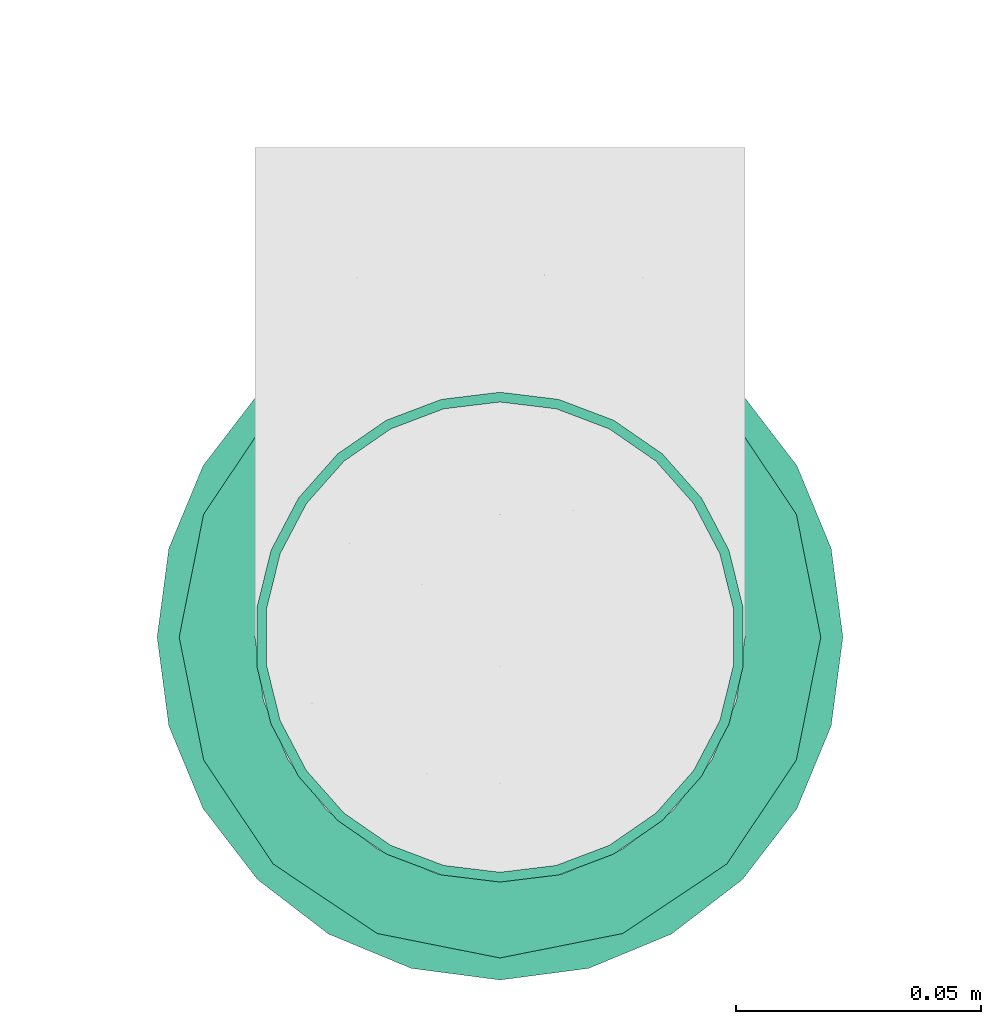
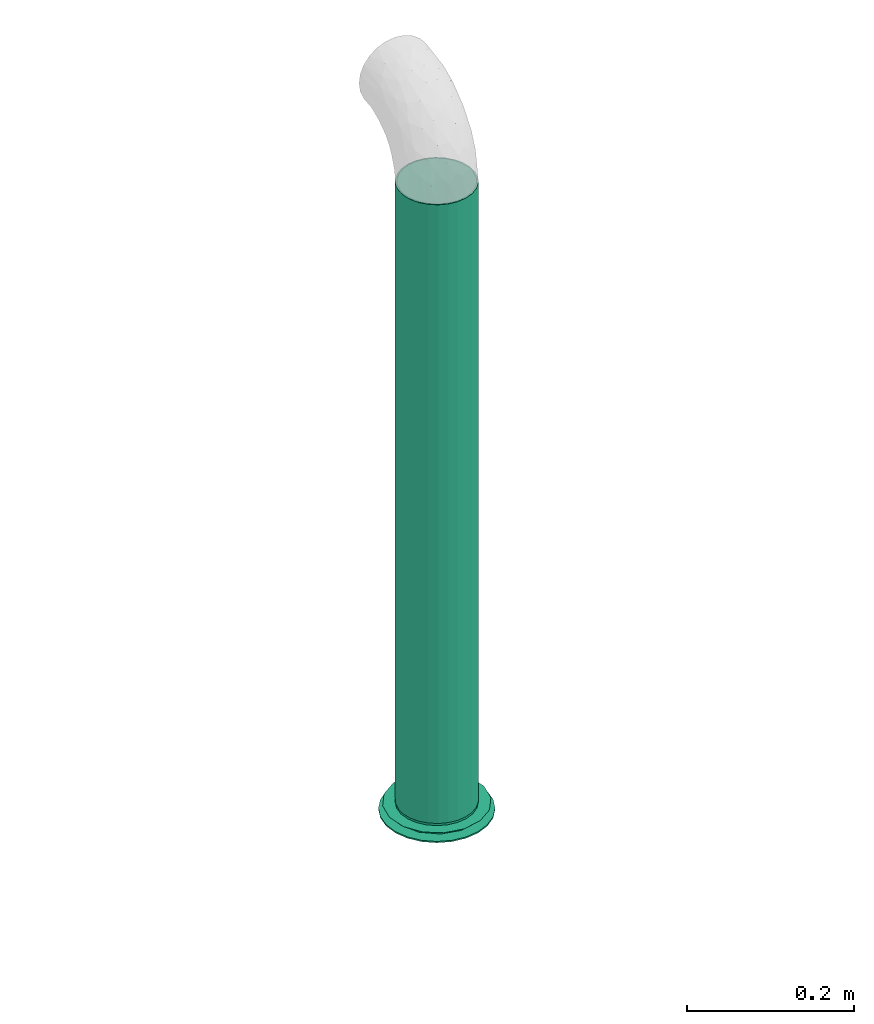
# One storey, part 49 of 103: 1 flow segment, 1 flow terminal.
"""IFC2X3 building model written with IfcOpenShell, lengths in millimetres."""

from ifc_helpers import new_model, entity, si_unit, converted_unit, derived_unit, direction, frame, origin_with_axes, origin_2d_with_axis, place, context, subcontext, project, spatial, hollow_circle, extrude, open_shell, surface_model, source, transform, mapped, material, layer, layer_set, layer_usage, type_object, element, save


model = new_model("IFC2X3")

# Units and contexts
model_context = context("Model", 3, precision=1e-05, world=origin_with_axes(), true_north=direction((0.0, 1.0)))
body_context = subcontext(model_context, "Body", "Model", "MODEL_VIEW")
ifc_project = project(units=[si_unit("AREAUNIT", "SQUARE_METRE"), si_unit("VOLUMEUNIT", "CUBIC_METRE", prefix="DECI"), si_unit("TIMEUNIT", "SECOND"), si_unit("THERMODYNAMICTEMPERATUREUNIT", "DEGREE_CELSIUS"), si_unit("PRESSUREUNIT", "PASCAL"), si_unit("MASSUNIT", "GRAM", prefix="KILO"), si_unit("LENGTHUNIT", "METRE", prefix="MILLI"), si_unit("POWERUNIT", "WATT"), si_unit("ELECTRICCURRENTUNIT", "AMPERE"), si_unit("ELECTRICVOLTAGEUNIT", "VOLT"), derived_unit("VOLUMETRICFLOWRATEUNIT", [(si_unit("VOLUMEUNIT", "CUBIC_METRE", prefix="DECI"), 1), (si_unit("TIMEUNIT", "SECOND"), -1)]), derived_unit("LINEARVELOCITYUNIT", [(si_unit("LENGTHUNIT", "METRE"), 1), (si_unit("TIMEUNIT", "SECOND"), -1)]), derived_unit("MASSDENSITYUNIT", [(si_unit("MASSUNIT", "GRAM", prefix="KILO"), 1), (si_unit("VOLUMEUNIT", "CUBIC_METRE"), -1)]), converted_unit("PLANEANGLEUNIT", "DEGREE", entity("IfcRatioMeasure", 0.01745), si_unit("PLANEANGLEUNIT", "RADIAN"), dimensions=[0, 0, 0, 0, 0, 0, 0])], contexts=[model_context])

# Site, building, storey
site_placement = place(None, origin_with_axes())
site = spatial("IfcSite", under=ifc_project, at=site_placement, CompositionType="ELEMENT")
building_placement = place(site_placement, origin_with_axes())
building = spatial("IfcBuilding", under=site, at=building_placement, Name="mc-building", CompositionType="ELEMENT")
storey_placement = place(building_placement, frame((0.0, 0.0, 5900.0), z_axis=(0.0, 0.0, 1.0), x_axis=(1.0, 0.0, 0.0)))
storey = spatial("IfcBuildingStorey", under=building, at=storey_placement, Name="3. Korrus", CompositionType="ELEMENT", Elevation=5900.0)

# Flow segment
ifc_material = material(Name="FZ1")
ifc_layer = layer(ifc_material, 0.0)
ifc_layer_set = layer_set([ifc_layer], Name="FZ1")
ifc_layer_usage = layer_usage(ifc_layer_set, "AXIS1", "POSITIVE", 0.0)
duct_segment_type = type_object("IfcDuctSegmentType", Name="Safe", PredefinedType="RIGIDSEGMENT")
shared_shape_1 = source(origin_with_axes(), body_context, "Body", "SweptSolid", [
    extrude(hollow_circle(Radius=50.0, WallThickness=2.0, at=origin_2d_with_axis()), frame((0.0, 0.0, 0.0), z_axis=(1.0, 0.0, 0.0), x_axis=(0.0, 1.0, 0.0)), (0.0, 0.0, 1.0), 906.0),
])
flow_segment_placement = place(storey_placement, frame((18753.74821, 573.88887, 2461.97044), z_axis=(1.0, 0.0, 0.0), x_axis=(0.0, 0.0, 1.0)))
element("IfcFlowSegment", 1, at=flow_segment_placement, inside=storey, type_object=duct_segment_type, material=ifc_layer_usage, Name="Safe", context=body_context, shape_type="MappedRepresentation", body=[
    mapped(shared_shape_1, transform((0.0, 0.0, 0.0), scale=1.0)),
])

# Flow terminal
air_terminal_type = type_object("IfcAirTerminalType", Name="100", PredefinedType="NOTDEFINED")
shared_shape_2 = source(origin_with_axes(), body_context, "Body", "SurfaceModel", [
    surface_model("IfcShellBasedSurfaceModel", [(11.2, -70.0, 0.0), (11.2, -67.61481, -18.11733), (11.2, -67.61481, 18.11733), (6.2, -14.64625, -20.15883), (9.2, -22.36867, -22.36867), (6.2, -21.19625, -15.39997), (9.2, 16.375, -28.36233), (6.2, 8.09625, -24.91768), (6.2, 14.64625, -20.15883), (6.2, -8.09625, -24.91768), (9.2, -16.375, -28.36233), (6.2, 21.19625, -15.39997), (9.2, 22.36867, -22.36867), (9.2, -8.1875, -30.55617), (9.2, 8.1875, -30.55617), (9.2, 28.36233, -16.375), (9.2, -28.36233, -16.375), (6.2, 14.64625, 20.15883), (9.2, 22.36867, 22.36867), (6.2, 21.19625, 15.39997), (9.2, -16.375, 28.36233), (6.2, -8.09625, 24.91768), (6.2, -14.64625, 20.15883), (6.2, 8.09625, 24.91768), (9.2, 16.375, 28.36233), (6.2, -21.19625, 15.39997), (9.2, -22.36867, 22.36867), (9.2, 8.1875, 30.55617), (9.2, -8.1875, 30.55617), (9.2, -28.36233, 16.375), (9.2, 28.36233, 16.375), (6.2, -53.11211, -25.57744), (6.2, -36.75472, -46.08897), (6.2, -13.11761, -57.472), (6.2, 13.11761, -57.472), (6.2, 36.75472, -46.08897), (6.2, 53.11211, -25.57744), (0.0, -12.53288, -63.00706), (6.2, 0.0, -57.472), (0.0, -46.3155, -46.3155), (0.0, -35.69063, -53.4148), (0.0, 0.0, -65.5), (6.2, 44.93342, -35.83321), (0.0, 46.3155, -46.3155), (0.0, 35.69063, -53.4148), (6.2, -44.93342, -35.83321), (0.0, 12.53288, -63.00706), (0.0, 25.06576, -60.51411), (6.2, 56.03105, -12.78872), (0.0, 60.51411, -25.06576), (0.0, 63.00706, -12.53288), (0.0, 53.4148, -35.69063), (0.0, -25.06576, -60.51411), (0.0, -63.00706, -12.53288), (0.0, -60.51411, -25.06576), (6.2, -56.03105, -12.78872), (0.0, -53.4148, -35.69063), (6.2, 13.11761, 57.472), (0.0, 12.53288, 63.00706), (6.2, 0.0, 57.472), (6.2, 36.75472, 46.08897), (0.0, 46.3155, 46.3155), (0.0, 35.69063, 53.4148), (0.0, 0.0, 65.5), (6.2, -44.93342, 35.83321), (6.2, -36.75472, 46.08897), (0.0, -46.3155, 46.3155), (0.0, -35.69063, 53.4148), (6.2, 44.93342, 35.83321), (0.0, -12.53288, 63.00706), (0.0, -25.06576, 60.51411), (6.2, -13.11761, 57.472), (6.2, -56.03105, 12.78872), (0.0, -60.51411, 25.06576), (0.0, -63.00706, 12.53288), (0.0, -53.4148, 35.69063), (0.0, 25.06576, 60.51411), (0.0, 63.00706, 12.53288), (0.0, 60.51411, 25.06576), (6.2, 56.03105, 12.78872), (0.0, 53.4148, 35.69063), (-3.1, 43.30127, 25.0), (-3.1, -48.29629, -12.94095), (-3.1, -43.30127, 25.0), (-3.1, 25.0, -43.30127), (-3.1, 48.29629, -12.94095), (-3.1, 35.35534, -35.35534), (-3.1, -35.35534, -35.35534), (-3.1, -25.0, -43.30127), (-43.1, 43.46666, 11.64686), (-3.1, 38.97115, 22.5), (-3.1, 43.46666, 11.64686), (-3.1, 45.0, 0.0), (-43.1, 45.0, 0.0), (-3.1, 31.81981, 31.81981), (-43.1, 38.97115, 22.5), (-43.1, -38.97115, 22.5), (-3.1, -38.97115, 22.5), (-3.1, -31.81981, 31.81981), (-3.1, -43.46666, 11.64686), (-43.1, -43.46666, 11.64686), (-43.1, -45.0, 0.0), (-3.1, -45.0, 0.0), (-43.1, -43.46666, -11.64686), (-3.1, -38.97115, -22.5), (-3.1, -43.46666, -11.64686), (-3.1, -11.64686, -43.46666), (-3.1, -22.5, -38.97115), (-43.1, -22.5, -38.97115), (-3.1, -31.81981, -31.81981), (-43.1, -38.97115, -22.5), (-43.1, 22.5, -38.97115), (-3.1, 22.5, -38.97115), (-3.1, 11.64686, -43.46666), (-43.1, 38.97115, -22.5), (-3.1, 38.97115, -22.5), (-3.1, 31.81981, -31.81981), (-3.1, 43.46666, -11.64686), (-43.1, 43.46666, -11.64686), (11.2, -49.49747, -49.49747), (11.2, -35.0, -60.62178), (11.2, -18.11733, -67.61481), (11.2, 67.61481, 18.11733), (11.2, -60.62178, -35.0), (11.2, 18.11733, -67.61481), (11.2, 35.0, -60.62178), (11.2, 0.0, -70.0), (11.2, 60.62178, -35.0), (11.2, 67.61481, -18.11733), (11.2, 49.49747, -49.49747), (11.2, -49.49747, 49.49747), (11.2, -60.62178, 35.0), (11.2, -35.0, 60.62178), (11.2, -18.11733, 67.61481), (11.2, 0.0, 70.0), (11.2, 60.62178, 35.0), (11.2, 49.49747, 49.49747), (11.2, 70.0, 0.0), (11.2, 35.0, 60.62178), (11.2, 18.11733, 67.61481), (9.2, -49.49747, 49.49747), (9.2, -35.0, 60.62178), (9.2, -18.11733, 67.61481), (9.2, -67.61481, 18.11733), (9.2, -70.0, 0.0), (9.2, -60.62178, 35.0), (9.2, 67.61481, 18.11733), (9.2, 35.0, 60.62178), (9.2, 18.11733, 67.61481), (9.2, 0.0, 70.0), (9.2, 60.62178, 35.0), (9.2, 49.49747, 49.49747), (9.2, -67.61481, -18.11733), (9.2, -49.49747, -49.49747), (9.2, -60.62178, -35.0), (9.2, -18.11733, -67.61481), (9.2, 70.0, 0.0), (9.2, -35.0, -60.62178), (9.2, 0.0, -70.0), (9.2, 60.62178, -35.0), (9.2, 49.49747, -49.49747), (9.2, 67.61481, -18.11733), (9.2, 35.0, -60.62178), (9.2, 18.11733, -67.61481), (9.2, -32.75, 0.0), (9.2, 0.0, 32.75), (9.2, 32.75, 0.0), (9.2, 0.0, -32.75), (6.2, 26.2, 0.0), (6.2, -26.2, 0.0), (9.2, -31.06579, -6.28555), (6.2, -23.69812, -7.69999), (6.2, 23.69812, -7.69999), (9.2, 31.06579, -6.28555), (6.2, 0.0, -24.91768), (9.2, 31.06579, 6.28555), (6.2, 23.69812, 7.69999), (6.2, -23.69812, 7.69999), (9.2, -31.06579, 6.28555), (6.2, 0.0, 24.91768), (6.2, 53.11211, 25.57744), (6.2, 58.95, 0.0), (6.2, -53.11211, 25.57744), (6.2, -58.95, 0.0), (0.0, 65.5, 0.0), (0.0, -65.5, 0.0), (6.2, -24.93616, -51.78048), (6.2, 24.93616, -51.78048), (6.2, 24.93616, 51.78048), (6.2, -24.93616, 51.78048), (-3.1, 0.0, 50.0), (-3.1, 35.35534, 35.35534), (-3.1, -12.94095, 48.29629), (-3.1, -25.0, 43.30127), (-3.1, -35.35534, 35.35534), (-3.1, 25.0, 43.30127), (-3.1, 12.94095, 48.29629), (-3.1, 48.29629, 12.94095), (-3.1, 50.0, 0.0), (-3.1, -50.0, 0.0), (-3.1, -48.29629, 12.94095), (-3.1, -43.30127, -25.0), (-3.1, -12.94095, -48.29629), (-3.1, 0.0, -50.0), (-3.1, 43.30127, -25.0), (-3.1, 12.94095, -48.29629), (0.0, -12.94095, -48.29629), (0.0, 0.0, -50.0), (0.0, -25.0, -43.30127), (0.0, -35.35534, -35.35534), (0.0, -48.29629, -12.94095), (0.0, 25.0, -43.30127), (0.0, -43.30127, -25.0), (0.0, 43.30127, 25.0), (0.0, 12.94095, -48.29629), (0.0, 43.30127, -25.0), (0.0, 48.29629, -12.94095), (0.0, 35.35534, -35.35534), (0.0, 50.0, 0.0), (0.0, -50.0, 0.0), (0.0, -48.29629, 12.94095), (0.0, -43.30127, 25.0), (0.0, -35.35534, 35.35534), (0.0, -12.94095, 48.29629), (0.0, -25.0, 43.30127), (0.0, 35.35534, 35.35534), (0.0, 0.0, 50.0), (0.0, 48.29629, 12.94095), (0.0, 25.0, 43.30127), (0.0, 12.94095, 48.29629), (-43.1, -22.5, 38.97115), (-43.1, -11.64686, 43.46666), (-43.1, 0.0, 45.0), (-43.1, 11.64686, 43.46666), (-43.1, -31.81981, 31.81981), (-43.1, 31.81981, 31.81981), (-43.1, 22.5, 38.97115), (-43.1, -31.81981, -31.81981), (-43.1, 31.81981, -31.81981), (-43.1, -11.64686, -43.46666), (-43.1, 11.64686, -43.46666), (-43.1, 0.0, -45.0), (-3.1, 0.0, -45.0), (-3.1, 0.0, 45.0), (-3.1, -22.5, 38.97115), (-3.1, -11.64686, 43.46666), (-3.1, 11.64686, 43.46666), (-3.1, 22.5, 38.97115)], [open_shell([[[0, 1, 2]], [[3, 4, 5]], [[6, 7, 8]], [[3, 9, 10]], [[4, 3, 10]], [[11, 12, 8]], [[13, 10, 9]], [[7, 6, 14]], [[6, 8, 12]], [[12, 11, 15]], [[16, 5, 4]], [[17, 18, 19]], [[20, 21, 22]], [[17, 23, 24]], [[18, 17, 24]], [[25, 26, 22]], [[27, 24, 23]], [[21, 20, 28]], [[20, 22, 26]], [[26, 25, 29]], [[30, 19, 18]], [[31, 32, 33]], [[34, 35, 36]], [[33, 37, 38]], [[32, 39, 40]], [[41, 38, 37]], [[42, 35, 43]], [[44, 43, 35]], [[39, 32, 45]], [[46, 47, 34]], [[48, 49, 50]], [[38, 46, 34]], [[42, 43, 51]], [[33, 52, 37]], [[53, 54, 55]], [[46, 38, 41]], [[56, 39, 45]], [[57, 58, 59]], [[60, 61, 62]], [[63, 59, 58]], [[64, 65, 66]], [[67, 66, 65]], [[61, 60, 68]], [[69, 70, 71]], [[72, 73, 74]], [[59, 69, 71]], [[64, 66, 75]], [[57, 76, 58]], [[77, 78, 79]], [[69, 59, 63]], [[80, 61, 68]], [[81, 82, 83]], [[84, 85, 86]], [[87, 82, 88]], [[89, 90, 91]], [[91, 92, 93]], [[94, 90, 95]], [[96, 97, 98]], [[99, 97, 100]], [[101, 102, 99]], [[103, 104, 105]], [[105, 102, 101]], [[106, 107, 108]], [[109, 104, 110]], [[111, 112, 113]], [[114, 115, 116]], [[117, 115, 118]], [[93, 92, 117]], [[119, 120, 121]], [[1, 119, 121]], [[122, 1, 121]], [[123, 119, 1]], [[124, 122, 121]], [[125, 122, 124]], [[121, 126, 124]], [[127, 128, 129]], [[129, 128, 122]], [[129, 122, 125]], [[130, 131, 2]], [[132, 130, 2]], [[122, 133, 2]], [[132, 2, 133]], [[134, 133, 122]], [[135, 136, 122]], [[122, 128, 137]], [[136, 138, 122]], [[139, 122, 138]], [[122, 139, 134]], [[2, 1, 122]], [[140, 141, 142]], [[143, 140, 142]], [[142, 144, 143]], [[145, 140, 143]], [[146, 144, 142]], [[147, 146, 148]], [[149, 148, 146]], [[150, 146, 151]], [[147, 151, 146]], [[146, 142, 149]], [[146, 152, 144]], [[153, 154, 152]], [[155, 153, 152]], [[146, 156, 155]], [[157, 153, 155]], [[158, 155, 156]], [[159, 160, 161]], [[156, 161, 160]], [[160, 162, 156]], [[163, 156, 162]], [[163, 158, 156]], [[152, 146, 155]], [[156, 128, 161]], [[161, 127, 159]], [[162, 160, 125]], [[129, 160, 159]], [[163, 162, 124]], [[128, 127, 161]], [[156, 137, 128]], [[162, 125, 124]], [[125, 160, 129]], [[159, 127, 129]], [[163, 124, 126]], [[126, 158, 163]], [[158, 121, 155]], [[155, 120, 157]], [[154, 153, 123]], [[119, 153, 157]], [[152, 154, 1]], [[120, 119, 157]], [[155, 121, 120]], [[152, 1, 0]], [[1, 154, 123]], [[153, 119, 123]], [[152, 0, 144]], [[126, 121, 158]], [[144, 2, 143]], [[143, 131, 145]], [[141, 140, 132]], [[130, 140, 145]], [[142, 141, 133]], [[2, 131, 143]], [[144, 0, 2]], [[141, 132, 133]], [[132, 140, 130]], [[145, 131, 130]], [[142, 133, 134]], [[134, 149, 142]], [[149, 139, 148]], [[148, 138, 147]], [[150, 151, 135]], [[136, 151, 147]], [[146, 150, 122]], [[138, 136, 147]], [[148, 139, 138]], [[146, 122, 137]], [[122, 150, 135]], [[151, 136, 135]], [[146, 137, 156]], [[134, 139, 149]], [[30, 24, 164]], [[24, 20, 164]], [[165, 20, 24]], [[164, 20, 29]], [[166, 30, 16]], [[16, 6, 166]], [[167, 6, 10]], [[30, 164, 16]], [[10, 6, 16]], [[6, 15, 166]], [[21, 19, 11]], [[23, 19, 21]], [[11, 19, 168]], [[7, 25, 21]], [[7, 5, 169]], [[21, 11, 7]], [[9, 5, 7]], [[169, 25, 7]], [[170, 164, 169]], [[170, 171, 16]], [[11, 172, 15]], [[172, 168, 173]], [[174, 13, 9]], [[166, 173, 168]], [[172, 173, 15]], [[169, 171, 170]], [[5, 16, 171]], [[167, 174, 14]], [[174, 167, 13]], [[14, 174, 7]], [[175, 166, 168]], [[175, 176, 30]], [[25, 177, 29]], [[177, 169, 178]], [[179, 27, 23]], [[164, 178, 169]], [[177, 178, 29]], [[168, 176, 175]], [[19, 30, 176]], [[165, 179, 28]], [[179, 165, 27]], [[28, 179, 21]], [[180, 60, 57]], [[181, 180, 65]], [[65, 57, 71]], [[180, 57, 65]], [[65, 182, 181]], [[182, 36, 181]], [[183, 34, 36]], [[31, 34, 183]], [[31, 33, 34]], [[182, 183, 36]], [[70, 63, 49]], [[70, 73, 66]], [[49, 63, 184]], [[78, 76, 61]], [[76, 78, 184]], [[184, 63, 76]], [[73, 70, 49]], [[39, 54, 185]], [[41, 39, 185]], [[52, 39, 41]], [[43, 185, 49]], [[185, 43, 47]], [[185, 47, 41]], [[73, 49, 185]], [[55, 54, 31]], [[31, 54, 56]], [[52, 186, 40]], [[53, 55, 183]], [[56, 45, 31]], [[185, 53, 183]], [[32, 40, 186]], [[33, 186, 52]], [[44, 35, 187]], [[49, 36, 51]], [[34, 47, 187]], [[42, 51, 36]], [[187, 47, 44]], [[49, 48, 36]], [[48, 50, 181]], [[184, 181, 50]], [[79, 78, 180]], [[180, 78, 80]], [[76, 188, 62]], [[77, 79, 181]], [[80, 68, 180]], [[184, 77, 181]], [[60, 62, 188]], [[57, 188, 76]], [[67, 65, 189]], [[73, 182, 75]], [[71, 70, 189]], [[64, 75, 182]], [[189, 70, 67]], [[73, 72, 182]], [[72, 74, 183]], [[185, 183, 74]], [[190, 191, 192]], [[193, 192, 194]], [[83, 192, 81]], [[194, 192, 83]], [[195, 191, 196]], [[191, 190, 196]], [[197, 198, 81]], [[81, 192, 191]], [[198, 84, 81]], [[199, 200, 83]], [[81, 88, 82]], [[201, 82, 87]], [[88, 81, 202]], [[81, 203, 202]], [[204, 86, 85]], [[205, 203, 84]], [[84, 198, 85]], [[81, 84, 203]], [[199, 83, 82]], [[206, 207, 208]], [[209, 208, 210]], [[210, 208, 211]], [[212, 209, 210]], [[210, 211, 213]], [[214, 211, 207]], [[211, 208, 207]], [[215, 216, 217]], [[211, 217, 216]], [[216, 218, 211]], [[219, 210, 220]], [[221, 210, 213]], [[222, 221, 223]], [[213, 223, 221]], [[224, 222, 223]], [[223, 225, 226]], [[227, 213, 218]], [[218, 213, 211]], [[228, 229, 225]], [[223, 213, 225]], [[226, 225, 229]], [[221, 220, 210]], [[199, 220, 200]], [[200, 221, 83]], [[193, 194, 224]], [[222, 194, 83]], [[192, 193, 223]], [[220, 221, 200]], [[199, 219, 220]], [[193, 224, 223]], [[224, 194, 222]], [[83, 221, 222]], [[192, 223, 226]], [[226, 190, 192]], [[190, 229, 196]], [[196, 228, 195]], [[81, 191, 213]], [[225, 191, 195]], [[197, 81, 227]], [[228, 225, 195]], [[196, 229, 228]], [[197, 227, 218]], [[227, 81, 213]], [[191, 225, 213]], [[197, 218, 198]], [[226, 229, 190]], [[198, 216, 85]], [[85, 215, 204]], [[84, 86, 211]], [[217, 86, 204]], [[205, 84, 214]], [[216, 215, 85]], [[198, 218, 216]], [[84, 211, 214]], [[211, 86, 217]], [[204, 215, 217]], [[205, 214, 207]], [[207, 203, 205]], [[203, 206, 202]], [[202, 208, 88]], [[201, 87, 212]], [[209, 87, 88]], [[82, 201, 210]], [[208, 209, 88]], [[202, 206, 208]], [[82, 210, 219]], [[210, 201, 212]], [[87, 209, 212]], [[82, 219, 199]], [[207, 206, 203]], [[230, 231, 232]], [[230, 232, 233]], [[230, 100, 96]], [[234, 230, 96]], [[100, 230, 233]], [[235, 89, 236]], [[100, 233, 236]], [[95, 89, 235]], [[118, 89, 93]], [[118, 236, 89]], [[118, 100, 236]], [[110, 103, 101]], [[237, 110, 101]], [[238, 108, 101]], [[237, 101, 108]], [[239, 108, 238]], [[114, 238, 118]], [[238, 101, 118]], [[240, 241, 111]], [[238, 111, 241]], [[238, 241, 239]], [[100, 118, 101]], [[106, 242, 107]], [[107, 112, 109]], [[102, 105, 104]], [[112, 104, 109]], [[92, 104, 117]], [[113, 112, 242]], [[112, 107, 242]], [[115, 117, 116]], [[112, 116, 117]], [[112, 117, 104]], [[92, 102, 104]], [[97, 99, 243]], [[98, 97, 244]], [[243, 245, 244]], [[97, 243, 244]], [[246, 243, 99]], [[90, 94, 91]], [[92, 91, 247]], [[94, 247, 91]], [[247, 99, 92]], [[247, 246, 99]], [[102, 92, 99]], [[101, 99, 100]], [[100, 97, 96]], [[230, 234, 244]], [[98, 234, 96]], [[231, 230, 245]], [[245, 230, 244]], [[244, 234, 98]], [[245, 243, 231]], [[243, 232, 231]], [[236, 233, 246]], [[236, 247, 235]], [[89, 95, 90]], [[94, 95, 235]], [[93, 89, 91]], [[232, 246, 233]], [[246, 247, 236]], [[243, 246, 232]], [[247, 94, 235]], [[93, 117, 118]], [[118, 115, 114]], [[111, 238, 112]], [[116, 238, 114]], [[240, 111, 113]], [[112, 238, 116]], [[240, 113, 242]], [[242, 241, 240]], [[108, 239, 106]], [[108, 107, 237]], [[103, 110, 104]], [[109, 110, 237]], [[101, 103, 105]], [[241, 106, 239]], [[242, 106, 241]], [[107, 109, 237]]])]),
])
flow_terminal_placement = place(storey_placement, frame((18753.74821, 573.88887, 2458.87044), z_axis=(1.0, 0.0, 0.0), x_axis=(0.0, 0.0, -1.0)))
element("IfcFlowTerminal", 2, at=flow_terminal_placement, inside=storey, type_object=air_terminal_type, Name="100", context=body_context, shape_type="MappedRepresentation", body=[
    mapped(shared_shape_2, transform((0.0, 0.0, 0.0), scale=1.0)),
])

save(model, "model.ifc")
